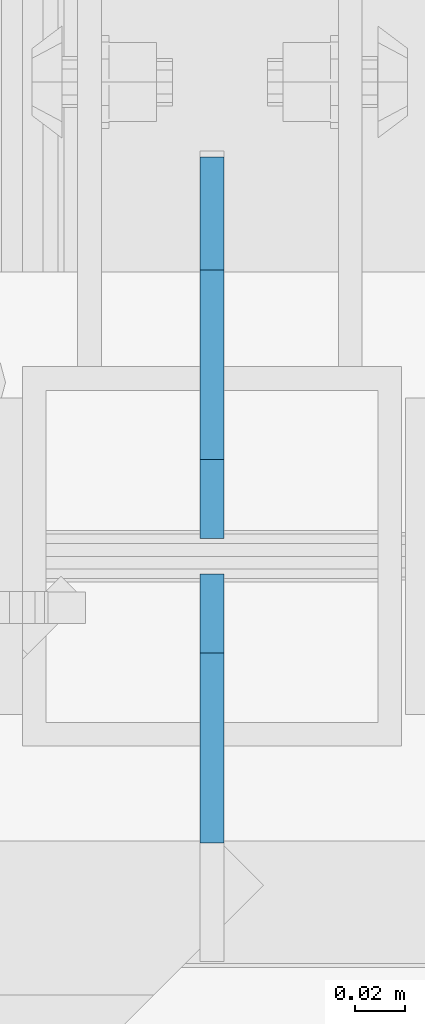
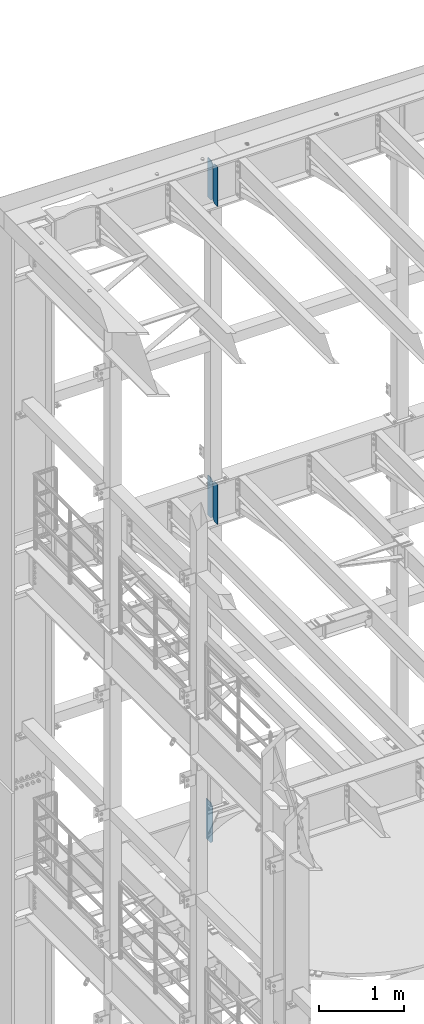
# One storey, part 1778 of 1876: 5 plates, 3 elements without a shape of their own.
"""IFC2X3 building model written with IfcOpenShell, lengths in millimetres."""

from ifc_helpers import new_model, si_unit, frame, origin_with_axes, place, context, subcontext, project, spatial, faceted_brep, material, type_object, element, aggregate, save


model = new_model("IFC2X3")

# Units and contexts
model_context = context("Model", 3, precision=1e-05, world=origin_with_axes())
body_context = subcontext(model_context, "Body", "Model", "MODEL_VIEW")
ifc_project = project(units=[si_unit("LENGTHUNIT", "METRE", prefix="MILLI"), si_unit("AREAUNIT", "SQUARE_METRE"), si_unit("VOLUMEUNIT", "CUBIC_METRE"), si_unit("MASSUNIT", "GRAM", prefix="KILO"), si_unit("TIMEUNIT", "SECOND"), si_unit("PLANEANGLEUNIT", "RADIAN"), si_unit("SOLIDANGLEUNIT", "STERADIAN"), si_unit("THERMODYNAMICTEMPERATUREUNIT", "DEGREE_CELSIUS"), si_unit("LUMINOUSINTENSITYUNIT", "LUMEN")], contexts=[model_context])

# Site, building, storey
site_placement = place(None, origin_with_axes())
site = spatial("IfcSite", under=ifc_project, at=site_placement, CompositionType="ELEMENT")
building_placement = place(site_placement, origin_with_axes())
building = spatial("IfcBuilding", under=site, at=building_placement, Name="Undefined", CompositionType="ELEMENT")
storey_placement = place(building_placement, origin_with_axes())
storey = spatial("IfcBuildingStorey", under=building, at=storey_placement, Name="Undefined", CompositionType="ELEMENT", Elevation=0.0)

# Assembly, plate
assembly_1_placement = place(storey_placement, origin_with_axes())
assembly_1 = element("IfcElementAssembly", 1, at=assembly_1_placement, inside=storey, Name="BEAM", AssemblyPlace="NOTDEFINED", PredefinedType="RIGID_FRAME")
ifc_material = material(Name="STEEL/A36")
plate_type_1 = type_object("IfcPlateType", PredefinedType="NOTDEFINED")
plate_1_placement = place(assembly_1_placement, frame((2540.0, 13723.9375, 12707.9375), z_axis=(0.0, 0.0, 1.0), x_axis=(0.0, 1.0, 0.0)))
plate_1 = element("IfcPlate", 2, at=plate_1_placement, type_object=plate_type_1, material=ifc_material, Name="PLATE", context=body_context, shape_type="Brep", body=[
    faceted_brep([(0.0, -4.76249999999982, 38.0999984741211), (0.0, -4.76249999999982, 536.574989318848), (0.0, 4.76249999999982, 536.574989318848), (0.0, 4.76249999999982, 38.0999984741211), (38.0999984741211, -4.76249999999982, 574.674987792969), (38.0999984741211, 4.76249999999982, 574.674987792969), (152.39999389651, -4.76250000000255, 574.674987792969), (152.39999389651, 4.76249999999891, 574.674987792969), (152.399993896484, -4.76249999999982, 0.0), (152.399993896484, 4.76249999999982, 0.0), (38.0999984741211, -4.76249999999982, 0.0), (38.0999984741211, 4.76249999999982, 0.0)], [[[0, 1, 2, 3]], [[1, 4, 5, 2]], [[4, 6, 7, 5]], [[6, 8, 9, 7]], [[8, 10, 11, 9]], [[10, 0, 3, 11]], [[5, 7, 9, 11, 3, 2]], [[10, 8, 6, 4, 1, 0]]]),
])
aggregate(assembly_1, [plate_1])

# Assembly, plates
assembly_2_placement = place(storey_placement, origin_with_axes())
assembly_2 = element("IfcElementAssembly", 3, at=assembly_2_placement, inside=storey, Name="BEAM", AssemblyPlace="NOTDEFINED", PredefinedType="RIGID_FRAME")
plate_type_2 = type_object("IfcPlateType", PredefinedType="NOTDEFINED")
plate_2_placement = place(assembly_2_placement, frame((2540.0, 13600.90625, 21958.3), z_axis=(0.0, 0.0, 1.0), x_axis=(0.0, 1.0, 0.0)))
plate_2 = element("IfcPlate", 4, at=plate_2_placement, type_object=plate_type_2, material=ifc_material, Name="PLATE", context=body_context, shape_type="Brep", body=[
    faceted_brep([(0.0, -4.76249999999982, 0.0), (0.0, -4.76249999999982, 571.5), (0.0, 4.76249999999982, 571.5), (0.0, 4.76249999999982, 0.0), (76.1999969482422, -4.76249999999982, 571.5), (76.1999969482422, 4.76249999999982, 571.5), (107.949996948242, -4.76249999999982, 539.75), (107.949996948242, 4.76249999999982, 539.75), (107.949996948242, -4.76249999999982, 31.75), (107.949996948242, 4.76249999999982, 31.75), (76.1999969482422, -4.76250000000073, 0.0), (76.1999969482422, 4.76250000000073, 0.0)], [[[0, 1, 2, 3]], [[1, 4, 5, 2]], [[4, 6, 7, 5]], [[6, 8, 9, 7]], [[8, 10, 11, 9]], [[10, 0, 3, 11]], [[5, 7, 9, 11, 3, 2]], [[10, 8, 6, 4, 1, 0]]]),
])
plate_3_placement = place(assembly_2_placement, frame((2540.0, 13723.14375, 21958.3), z_axis=(0.0, 0.0, 1.0), x_axis=(0.0, 1.0, 0.0)))
plate_3 = element("IfcPlate", 5, at=plate_3_placement, type_object=plate_type_2, material=ifc_material, Name="PLATE", context=body_context, shape_type="Brep", body=[
    faceted_brep([(-9.76996261670138e-14, -4.76250000000073, 31.75), (0.0, -4.76249999999982, 539.75), (0.0, 4.76249999999982, 539.75), (-9.76996261670138e-14, 4.76250000000073, 31.75), (31.75, -4.76249999999982, 571.5), (31.75, 4.76249999999982, 571.5), (107.949996948242, -4.76249999999982, 571.5), (107.949996948242, 4.76249999999982, 571.5), (107.950006484985, -4.76250000000073, 0.0), (107.950006484985, 4.76250000000073, 0.0), (31.75, -4.76250000000073, 0.0), (31.75, 4.76250000000073, 0.0)], [[[0, 1, 2, 3]], [[1, 4, 5, 2]], [[4, 6, 7, 5]], [[6, 8, 9, 7]], [[8, 10, 11, 9]], [[10, 0, 3, 11]], [[5, 7, 9, 11, 3, 2]], [[10, 8, 6, 4, 1, 0]]]),
])
aggregate(assembly_2, [plate_2, plate_3])

assembly_3_placement = place(storey_placement, origin_with_axes())
assembly_3 = element("IfcElementAssembly", 6, at=assembly_3_placement, inside=storey, Name="BEAM", AssemblyPlace="NOTDEFINED", PredefinedType="RIGID_FRAME")
plate_4_placement = place(assembly_3_placement, frame((2540.0, 13600.90625, 17386.3), z_axis=(0.0, 0.0, 1.0), x_axis=(0.0, 1.0, 0.0)))
plate_4 = element("IfcPlate", 7, at=plate_4_placement, type_object=plate_type_2, material=ifc_material, Name="PLATE", context=body_context, shape_type="Brep", body=[
    faceted_brep([(0.0, -4.76249999999982, 0.0), (0.0, -4.76249999999982, 571.5), (0.0, 4.76249999999982, 571.5), (0.0, 4.76249999999982, 0.0), (76.1999969482422, -4.76249999999982, 571.5), (76.1999969482422, 4.76249999999982, 571.5), (107.949996948242, -4.76249999999982, 539.75), (107.949996948242, 4.76249999999982, 539.75), (107.949996948242, -4.76249999999982, 31.75), (107.949996948242, 4.76249999999982, 31.75), (76.1999969482422, -4.76250000000073, 0.0), (76.1999969482422, 4.76250000000073, 0.0)], [[[0, 1, 2, 3]], [[1, 4, 5, 2]], [[4, 6, 7, 5]], [[6, 8, 9, 7]], [[8, 10, 11, 9]], [[10, 0, 3, 11]], [[5, 7, 9, 11, 3, 2]], [[10, 8, 6, 4, 1, 0]]]),
])
plate_5_placement = place(assembly_3_placement, frame((2540.0, 13723.14375, 17386.3), z_axis=(0.0, 0.0, 1.0), x_axis=(0.0, 1.0, 0.0)))
plate_5 = element("IfcPlate", 8, at=plate_5_placement, type_object=plate_type_2, material=ifc_material, Name="PLATE", context=body_context, shape_type="Brep", body=[
    faceted_brep([(-9.76996261670138e-14, -4.76250000000073, 31.75), (0.0, -4.76249999999982, 539.75), (0.0, 4.76249999999982, 539.75), (-9.76996261670138e-14, 4.76250000000073, 31.75), (31.75, -4.76249999999982, 571.5), (31.75, 4.76249999999982, 571.5), (107.949996948242, -4.76249999999982, 571.5), (107.949996948242, 4.76249999999982, 571.5), (107.950006484985, -4.76250000000073, 0.0), (107.950006484985, 4.76250000000073, 0.0), (31.75, -4.76250000000073, 0.0), (31.75, 4.76250000000073, 0.0)], [[[0, 1, 2, 3]], [[1, 4, 5, 2]], [[4, 6, 7, 5]], [[6, 8, 9, 7]], [[8, 10, 11, 9]], [[10, 0, 3, 11]], [[5, 7, 9, 11, 3, 2]], [[10, 8, 6, 4, 1, 0]]]),
])
aggregate(assembly_3, [plate_4, plate_5])

save(model, "model.ifc")
